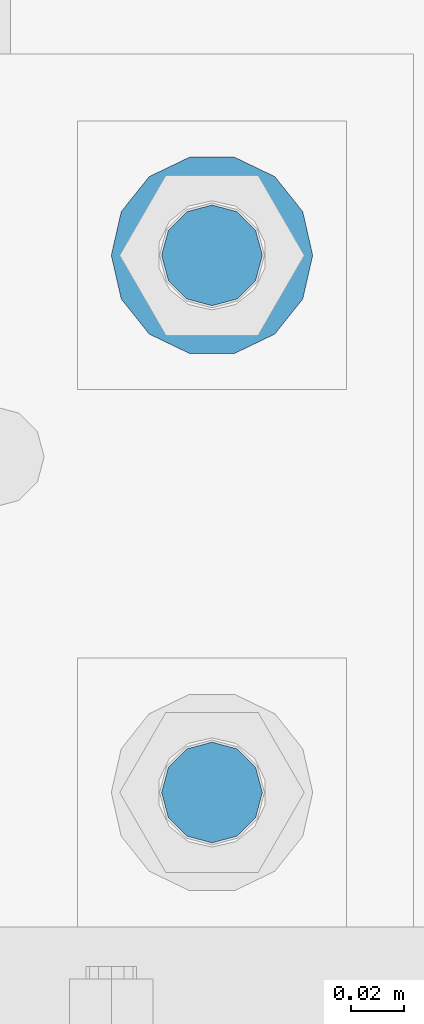
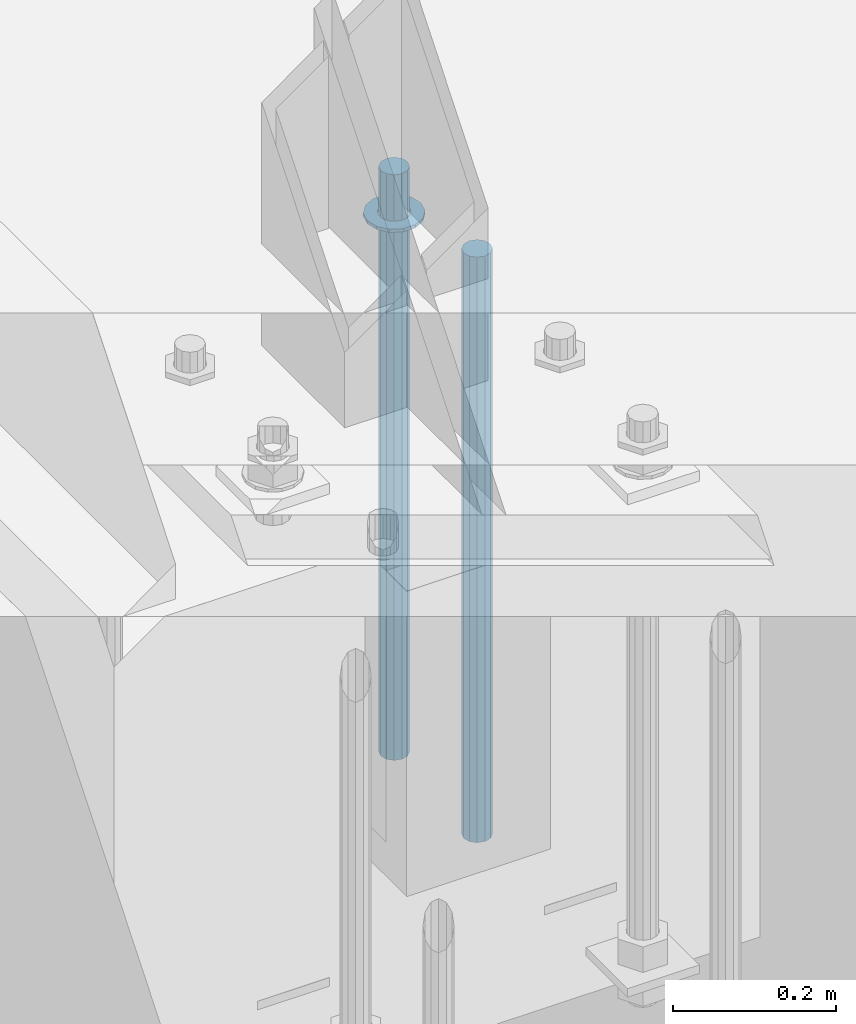
# One storey, part 927 of 1763: 3 columns, 1 element without a shape of its own.
"""IFC2X3 building model written with IfcOpenShell, lengths in millimetres."""

from ifc_helpers import new_model, si_unit, frame, origin_with_axes, place, context, subcontext, project, spatial, faceted_brep, material, type_object, element, aggregate, save


model = new_model("IFC2X3")

# Units and contexts
model_context = context("Model", 3, precision=1e-05, world=origin_with_axes())
body_context = subcontext(model_context, "Body", "Model", "MODEL_VIEW")
ifc_project = project(units=[si_unit("LENGTHUNIT", "METRE", prefix="MILLI"), si_unit("AREAUNIT", "SQUARE_METRE"), si_unit("VOLUMEUNIT", "CUBIC_METRE"), si_unit("MASSUNIT", "GRAM", prefix="KILO"), si_unit("TIMEUNIT", "SECOND"), si_unit("PLANEANGLEUNIT", "RADIAN"), si_unit("SOLIDANGLEUNIT", "STERADIAN"), si_unit("THERMODYNAMICTEMPERATUREUNIT", "DEGREE_CELSIUS"), si_unit("LUMINOUSINTENSITYUNIT", "LUMEN")], contexts=[model_context])

# Site, building, storey
site_placement = place(None, origin_with_axes())
site = spatial("IfcSite", under=ifc_project, at=site_placement, CompositionType="ELEMENT")
building_placement = place(site_placement, origin_with_axes())
building = spatial("IfcBuilding", under=site, at=building_placement, Name="Undefined", CompositionType="ELEMENT")
storey_placement = place(building_placement, origin_with_axes())
storey = spatial("IfcBuildingStorey", under=building, at=storey_placement, Name="Undefined", CompositionType="ELEMENT", Elevation=0.0)

# Assembly, columns
assembly_placement = place(storey_placement, origin_with_axes())
assembly = element("IfcElementAssembly", 1, at=assembly_placement, inside=storey, Name="TEMPLATE", AssemblyPlace="NOTDEFINED", PredefinedType="RIGID_FRAME")
ifc_material_1 = material(Name="STEEL/F436")
column_type_1 = type_object("IfcColumnType", Name="1-1/2_WASHER", PredefinedType="NOTDEFINED")
column_1_placement = place(assembly_placement, frame((-87172.2372736984, 8839.20000000001, 5151.43750000001), z_axis=(0.0, 1.0, 0.0), x_axis=(0.0, 0.0, -1.0)))
column_1 = element("IfcColumn", 2, at=column_1_placement, type_object=column_type_1, material=ifc_material_1, Name="WASHER", ObjectType="1-1/2_WASHER", context=body_context, shape_type="Brep", body=[
    faceted_brep([(0.0, -38.0999984741211, 0.0), (0.0, -34.3269124923099, -16.5309697983248), (4.76249999999982, -34.3269124923099, -16.5309697983248), (4.76249999999982, -38.0999984741211, 0.0), (0.0, -23.7549604994492, -29.7877782890519), (4.76249999999982, -23.7549604994492, -29.7877782890519), (0.0, -8.47804724419257, -37.1447519665053), (4.76249999999982, -8.47804724419257, -37.1447519665053), (0.0, 8.47804724419257, -37.1447519665053), (4.76249999999982, 8.47804724419257, -37.1447519665053), (0.0, 23.7549604994492, -29.7877782890519), (4.76249999999982, 23.7549604994492, -29.7877782890519), (0.0, 34.3269124923099, -16.5309697983248), (4.76249999999982, 34.3269124923099, -16.5309697983248), (0.0, 38.0999984741211, 0.0), (4.76249999999982, 38.0999984741211, 0.0), (0.0, 34.3269124923099, 16.5309697983248), (4.76249999999982, 34.3269124923099, 16.5309697983248), (0.0, 23.7549604994492, 29.7877782890519), (4.76249999999982, 23.7549604994492, 29.7877782890519), (0.0, 8.47804724419257, 37.1447519665053), (4.76249999999982, 8.47804724419257, 37.1447519665053), (0.0, -8.47804724419257, 37.1447519665053), (4.76249999999982, -8.47804724419257, 37.1447519665053), (0.0, -23.7549604994492, 29.7877782890519), (4.76249999999982, -23.7549604994492, 29.7877782890519), (0.0, -34.3269124923099, 16.5309697983248), (4.76249999999982, -34.3269124923099, 16.5309697983248), (0.0, 0.0, 20.6399993896484), (0.0, 8.95536011056538, 18.5959968835978), (4.76249999999982, 8.95536011056538, 18.5959968835978), (4.76249999999982, 0.0, 20.6399993896484), (0.0, 16.1370013209453, 12.8688291298167), (4.76249999999982, 16.1370013209453, 12.8688291298167), (0.0, 20.1225115123816, 4.59283194104137), (4.76249999999982, 20.1225115123816, 4.59283194104137), (0.0, 20.1225115123816, -4.59283194104319), (4.76249999999982, 20.1225115123816, -4.59283194104319), (0.0, 16.1370013209453, -12.8688291298167), (4.76249999999982, 16.1370013209453, -12.8688291298167), (0.0, 8.95536011056538, -18.5959968835978), (4.76249999999982, 8.95536011056538, -18.5959968835978), (0.0, 0.0, -20.6399993896484), (4.76249999999982, 0.0, -20.6399993896484), (0.0, -8.95536011056538, -18.5959968835978), (4.76249999999982, -8.95536011056538, -18.5959968835978), (0.0, -16.1370013209453, -12.8688291298167), (4.76249999999982, -16.1370013209453, -12.8688291298167), (0.0, -20.1225115123816, -4.59283194104137), (4.76249999999982, -20.1225115123816, -4.59283194104137), (0.0, -20.1225115123816, 4.59283194104319), (4.76249999999982, -20.1225115123816, 4.59283194104319), (0.0, -16.1370013209453, 12.8688291298167), (4.76249999999982, -16.1370013209453, 12.8688291298167), (0.0, -8.95536011056538, 18.5959968835978), (4.76249999999982, -8.95536011056538, 18.5959968835978)], [[[0, 1, 2, 3]], [[1, 4, 5, 2]], [[4, 6, 7, 5]], [[6, 8, 9, 7]], [[8, 10, 11, 9]], [[10, 12, 13, 11]], [[12, 14, 15, 13]], [[14, 16, 17, 15]], [[16, 18, 19, 17]], [[18, 20, 21, 19]], [[20, 22, 23, 21]], [[22, 24, 25, 23]], [[24, 26, 27, 25]], [[26, 0, 3, 27]], [[28, 29, 30, 31]], [[29, 32, 33, 30]], [[32, 34, 35, 33]], [[34, 36, 37, 35]], [[36, 38, 39, 37]], [[38, 40, 41, 39]], [[40, 42, 43, 41]], [[42, 44, 45, 43]], [[44, 46, 47, 45]], [[46, 48, 49, 47]], [[48, 50, 51, 49]], [[50, 52, 53, 51]], [[52, 54, 55, 53]], [[54, 28, 31, 55]], [[5, 7, 9, 11, 13, 15, 17, 19, 21, 23, 25, 27, 3, 2], [33, 35, 37, 39, 41, 43, 45, 47, 49, 51, 53, 55, 31, 30]], [[26, 24, 22, 20, 18, 16, 14, 12, 10, 8, 6, 4, 1, 0], [54, 52, 50, 48, 46, 44, 42, 40, 38, 36, 34, 32, 29, 28]]]),
])
ifc_material_2 = material(Name="STEEL/F1554-GR.55")
column_type_2 = type_object("IfcColumnType", PredefinedType="NOTDEFINED")
column_2_placement = place(assembly_placement, frame((-87172.2372736984, 8636.00000000001, 5219.70000000001), z_axis=(0.0, 1.0, 0.0), x_axis=(0.0, 0.0, -1.0)))
column_2 = element("IfcColumn", 3, at=column_2_placement, type_object=column_type_2, material=ifc_material_2, Name="ALL THREADED ROD", context=body_context, shape_type="Brep", body=[
    faceted_brep([(0.0, -19.0500000000029, 0.0), (0.0, -16.4977839420899, -9.52500000000146), (876.299, -16.4977839420899, -9.52499999999964), (876.299, -19.0500000000029, 0.0), (0.0, -9.52499999999418, -16.4977839420935), (876.299, -9.52499999999418, -16.4977839420935), (1.45519152283669e-11, 1.81898940354586e-12, -19.0499999999993), (876.299, 0.0, -19.0500000000002), (0.0, 9.52499999999418, -16.4977839420935), (876.299, 9.52499999999418, -16.4977839420935), (0.0, 16.4977839420899, -9.52500000000146), (876.299, 16.4977839420899, -9.52499999999964), (0.0, 19.0500000000029, 0.0), (876.299, 19.0500000000029, 0.0), (0.0, 16.4977839420899, 9.52500000000146), (876.299, 16.4977839420899, 9.52499999999964), (0.0, 9.52499999999418, 16.4977839420935), (876.299, 9.52499999999418, 16.4977839420935), (1.45519152283669e-11, 1.81898940354586e-12, 19.0499999999993), (876.299, 0.0, 19.0500000000002), (0.0, -9.52499999999418, 16.4977839420935), (876.299, -9.52499999999418, 16.4977839420935), (0.0, -16.4977839420899, 9.52500000000146), (876.299, -16.4977839420899, 9.52499999999964)], [[[0, 1, 2, 3]], [[1, 4, 5, 2]], [[4, 6, 7, 5]], [[6, 8, 9, 7]], [[8, 10, 11, 9]], [[10, 12, 13, 11]], [[12, 14, 15, 13]], [[14, 16, 17, 15]], [[16, 18, 19, 17]], [[18, 20, 21, 19]], [[20, 22, 23, 21]], [[22, 0, 3, 23]], [[5, 7, 9, 11, 13, 15, 17, 19, 21, 23, 3, 2]], [[22, 20, 18, 16, 14, 12, 10, 8, 6, 4, 1, 0]]]),
])
column_3_placement = place(assembly_placement, frame((-87172.2372736984, 8839.20000000001, 5219.70000000001), z_axis=(0.0, 1.0, 0.0), x_axis=(0.0, 0.0, -1.0)))
column_3 = element("IfcColumn", 4, at=column_3_placement, type_object=column_type_2, material=ifc_material_2, Name="ALL THREADED ROD", context=body_context, shape_type="Brep", body=[
    faceted_brep([(0.0, -19.0500000000029, 0.0), (0.0, -16.4977839420899, -9.52500000000146), (876.299, -16.4977839420899, -9.52499999999964), (876.299, -19.0500000000029, 0.0), (0.0, -9.52499999999418, -16.4977839420935), (876.299, -9.52499999999418, -16.4977839420935), (1.45519152283669e-11, 1.81898940354586e-12, -19.0499999999993), (876.299, 0.0, -19.0500000000002), (0.0, 9.52499999999418, -16.4977839420935), (876.299, 9.52499999999418, -16.4977839420935), (0.0, 16.4977839420899, -9.52500000000146), (876.299, 16.4977839420899, -9.52499999999964), (0.0, 19.0500000000029, 0.0), (876.299, 19.0500000000029, 0.0), (0.0, 16.4977839420899, 9.52500000000146), (876.299, 16.4977839420899, 9.52499999999964), (0.0, 9.52499999999418, 16.4977839420935), (876.299, 9.52499999999418, 16.4977839420935), (1.45519152283669e-11, 1.81898940354586e-12, 19.0499999999993), (876.299, 0.0, 19.0500000000002), (0.0, -9.52499999999418, 16.4977839420935), (876.299, -9.52499999999418, 16.4977839420935), (0.0, -16.4977839420899, 9.52500000000146), (876.299, -16.4977839420899, 9.52499999999964)], [[[0, 1, 2, 3]], [[1, 4, 5, 2]], [[4, 6, 7, 5]], [[6, 8, 9, 7]], [[8, 10, 11, 9]], [[10, 12, 13, 11]], [[12, 14, 15, 13]], [[14, 16, 17, 15]], [[16, 18, 19, 17]], [[18, 20, 21, 19]], [[20, 22, 23, 21]], [[22, 0, 3, 23]], [[5, 7, 9, 11, 13, 15, 17, 19, 21, 23, 3, 2]], [[22, 20, 18, 16, 14, 12, 10, 8, 6, 4, 1, 0]]]),
])
aggregate(assembly, [column_2, column_1, column_3])

save(model, "model.ifc")
